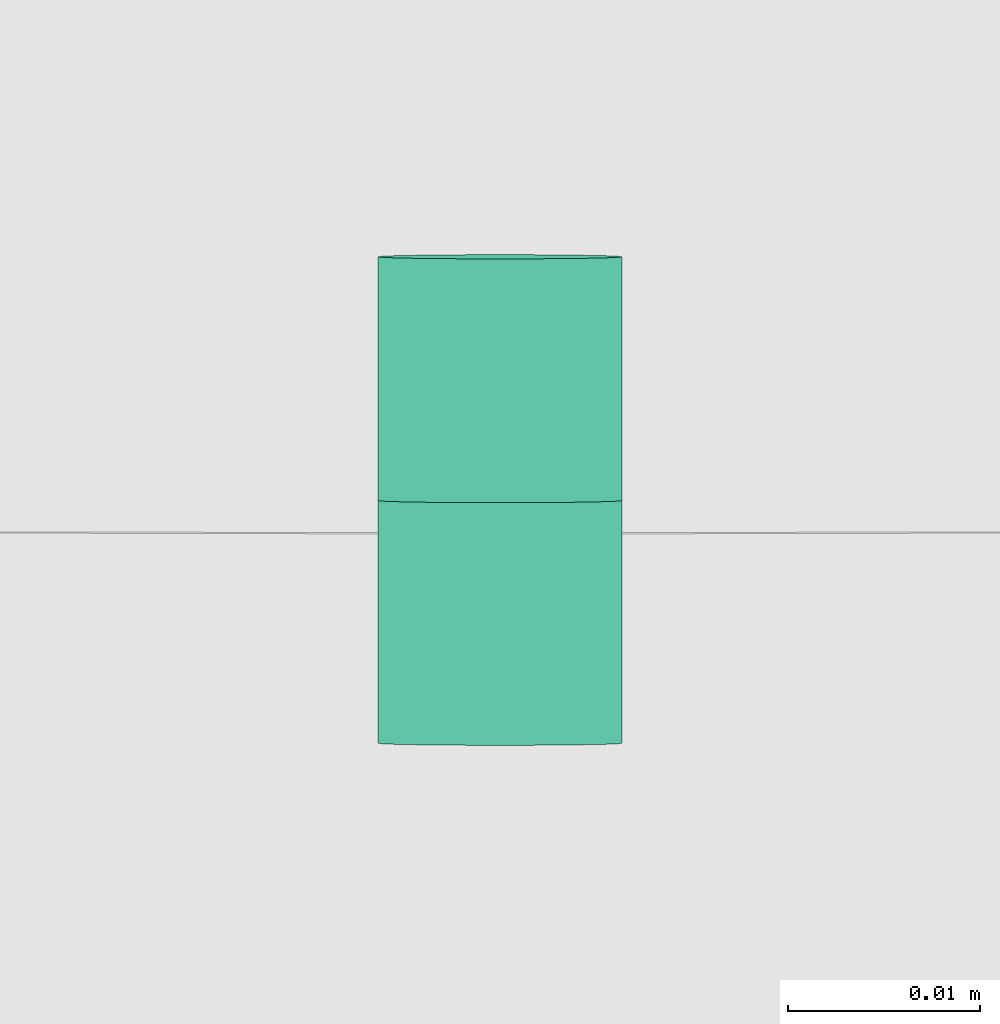
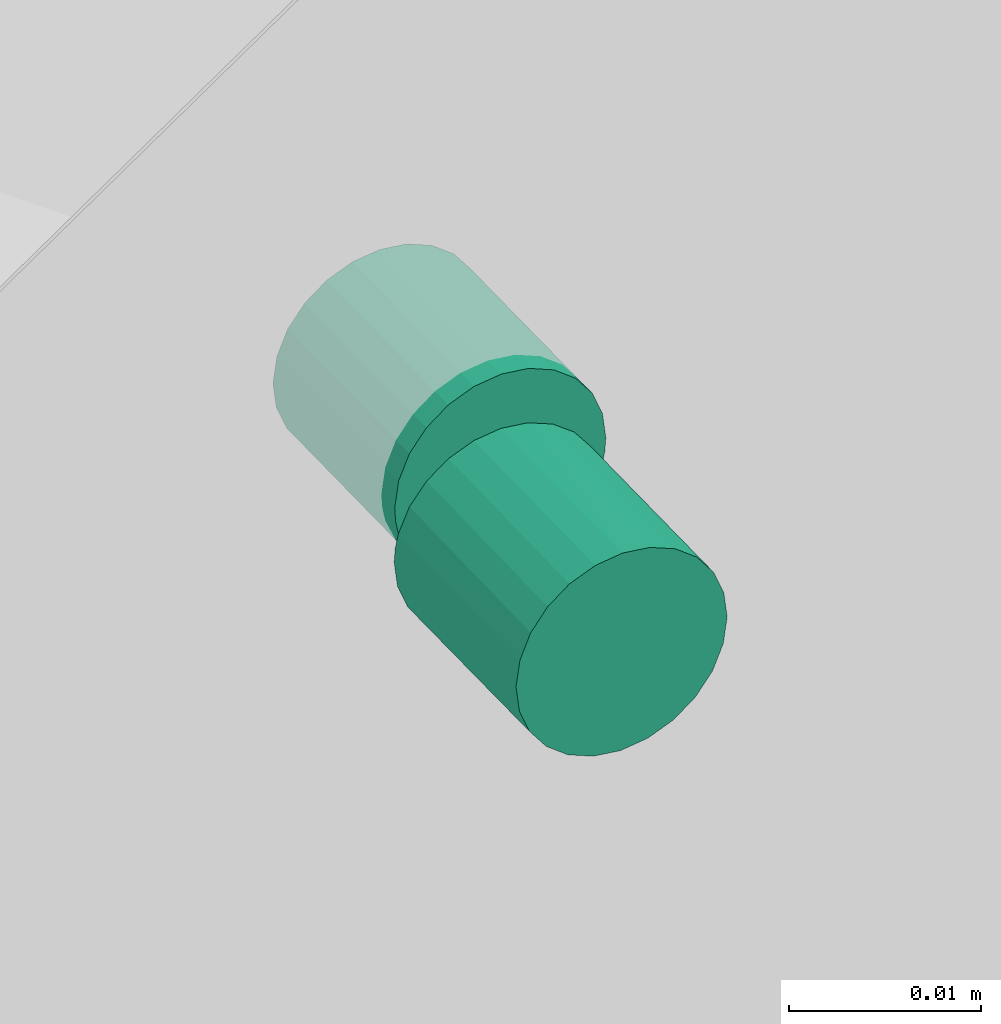
# One storey, part 60 of 60: 1 flow fitting.
"""IFC2X3 building model written with IfcOpenShell, lengths in millimetres."""

import ifcopenshell
import ifcopenshell.guid

model = None  # the IFC model being written
_history = None  # IfcOwnerHistory: only IFC2X3 demands one
_inside = {}  # id of a spatial element -> (the spatial element, [elements in it])
_under = {}  # id of a project, library or spatial element -> (it, [spatial elements below it])
_declared = {}  # id of a project -> (the project, [libraries it declares])
_typed = {}  # id of a type object -> (the type object, [elements of that type])
_made_of = {}  # id of a material, layer set ... -> (it, [elements and type objects made of it])


def new_model(schema):
    """Start an empty IFC model of exactly this schema.

    Asked for "IFC4X3", IfcOpenShell would pick the latest addendum, in which some entities
    have other attributes; the version numbers below select the first issue.
    IFC2X3 requires an IfcOwnerHistory on every rooted entity: one is made here for all.
    """
    global model, _history
    if schema == "IFC4X3":
        model = ifcopenshell.file(schema_version=(4, 3, 0, 0))
    else:
        model = ifcopenshell.file(schema=schema)
    _inside.clear()
    _under.clear()
    _declared.clear()
    _typed.clear()
    _made_of.clear()
    _history = None
    if model.schema == "IFC2X3":
        org = make("IfcOrganization", Name="unknown")
        user = make(
            "IfcPersonAndOrganization",
            ThePerson=make("IfcPerson", FamilyName="unknown"),
            TheOrganization=org,
        )
        app = make(
            "IfcApplication",
            ApplicationDeveloper=org,
            Version="unknown",
            ApplicationFullName="unknown",
            ApplicationIdentifier="unknown",
        )
        _history = make(
            "IfcOwnerHistory",
            OwningUser=user,
            OwningApplication=app,
            ChangeAction="ADDED",
            CreationDate=0,
        )
    return model


def make(cls, **values):
    """One entity of the class cls with the attributes given. An attribute that is None is left unset."""
    return model.create_entity(
        cls, **{name: value for name, value in values.items() if value is not None}
    )


def entity(cls, *values):
    """Any entity or typed value of the class cls, its attributes in the order of the schema. None: left unset."""
    e = model.create_entity(cls)
    for i, value in enumerate(values):
        if value is not None:
            e[i] = value
    return e


def rooted(cls, **values):
    """An entity with a GlobalId (a new one), such as an element, a storey or a relation."""
    return make(cls, GlobalId=ifcopenshell.guid.new(), OwnerHistory=_history, **values)


def si_unit(unit_type, name, prefix=None):
    """IfcSIUnit, for example si_unit("LENGTHUNIT", "METRE", prefix="MILLI")."""
    return make("IfcSIUnit", UnitType=unit_type, Prefix=prefix, Name=name)


def converted_unit(unit_type, name, factor, base, dimensions=None, offset=None):
    """IfcConversionBasedUnit, such as the inch: factor (a typed value) times the base unit."""
    return make(
        "IfcConversionBasedUnit"
        if offset is None
        else "IfcConversionBasedUnitWithOffset",
        ConversionOffset=offset,
        Dimensions=None
        if dimensions is None
        else entity("IfcDimensionalExponents", *dimensions),
        UnitType=unit_type,
        Name=name,
        ConversionFactor=make(
            "IfcMeasureWithUnit", ValueComponent=factor, UnitComponent=base
        ),
    )


def derived_unit(unit_type, elements):
    """IfcDerivedUnit: a product of units, each with its exponent."""
    return make(
        "IfcDerivedUnit",
        Elements=[
            make("IfcDerivedUnitElement", Unit=unit, Exponent=power)
            for unit, power in elements
        ],
        UnitType=unit_type,
    )


def assignment(units):
    """IfcUnitAssignment: the units of a project."""
    return None if units is None else make("IfcUnitAssignment", Units=units)


def point(xyz):
    """IfcCartesianPoint."""
    return None if xyz is None else make("IfcCartesianPoint", Coordinates=xyz)


def direction(xyz):
    """IfcDirection."""
    return None if xyz is None else make("IfcDirection", DirectionRatios=xyz)


def frame(location, z_axis=None, x_axis=None):
    """IfcAxis2Placement3D, a coordinate frame: its origin and axes. An axis left out is left unset."""
    return make(
        "IfcAxis2Placement3D",
        Location=point(location),
        Axis=direction(z_axis),
        RefDirection=direction(x_axis),
    )


def origin():
    """The frame at (0, 0, 0) with its axes left unset."""
    return frame((0.0, 0.0, 0.0))


def place(relative_to, where):
    """IfcLocalPlacement: puts the frame where relative to a parent placement (None: the world)."""
    return make(
        "IfcLocalPlacement", PlacementRelTo=relative_to, RelativePlacement=where
    )


def context(
    kind, dimensions, precision=None, world=None, true_north=None, identifier=None
):
    """IfcGeometricRepresentationContext, for example the 3D "Model" context."""
    return make(
        "IfcGeometricRepresentationContext",
        ContextIdentifier=identifier,
        ContextType=kind,
        CoordinateSpaceDimension=dimensions,
        Precision=precision,
        WorldCoordinateSystem=world,
        TrueNorth=true_north,
    )


def subcontext(parent, identifier, kind, view, scale=None):
    """IfcGeometricRepresentationSubContext, for example "Body" below "Model"."""
    return make(
        "IfcGeometricRepresentationSubContext",
        ContextIdentifier=identifier,
        ContextType=kind,
        ParentContext=parent,
        TargetScale=scale,
        TargetView=view,
    )


def project(units=None, contexts=None):
    """IfcProject with its units and contexts."""
    return rooted(
        "IfcProject",
        Name="project",
        RepresentationContexts=contexts,
        UnitsInContext=assignment(units),
    )


def spatial(cls, under=None, at=None, **own):
    """A site, building, storey or space (cls), placed at a placement, below another one or the project."""
    s = rooted(cls, ObjectPlacement=at, **own)
    if under is not None:
        _under.setdefault(under.id(), (under, []))[1].append(s)
    return s


def faces_of(points, faces, orient=None, outer=None):
    """IfcFace entities. A face is a list of loops; a loop is a list of indices into points, from 0.

    orient and outer hold one flag for each loop. By default every Orientation is true, the
    first loop of a face is its IfcFaceOuterBound and the others are IfcFaceBound.
    """
    made = []
    for i, loops in enumerate(faces):
        bounds = []
        for j, loop in enumerate(loops):
            is_outer = j == 0 if outer is None else outer[i][j]
            bounds.append(
                make(
                    "IfcFaceOuterBound" if is_outer else "IfcFaceBound",
                    Bound=make("IfcPolyLoop", Polygon=[points[k] for k in loop]),
                    Orientation=True if orient is None else orient[i][j],
                )
            )
        made.append(make("IfcFace", Bounds=bounds))
    return made


def faceted_brep(points, faces, orient=None, outer=None, voids=None):
    """IfcFacetedBrep: a solid bounded by flat faces; with voids (closed shells), ...WithVoids."""
    shared = [point(p) for p in points]
    hull = make("IfcClosedShell", CfsFaces=faces_of(shared, faces, orient, outer))
    if voids is None:
        return make("IfcFacetedBrep", Outer=hull)
    return make(
        "IfcFacetedBrepWithVoids",
        Outer=hull,
        Voids=[
            make(cls, CfsFaces=faces_of(shared, fs, o, b)) for cls, fs, o, b in voids
        ],
    )


def shape(context_of_items, identifier, shape_type, items):
    """IfcShapeRepresentation: the items that make up one representation, for example the "Body"."""
    return make(
        "IfcShapeRepresentation",
        ContextOfItems=context_of_items,
        RepresentationIdentifier=identifier,
        RepresentationType=shape_type,
        Items=items,
    )


def source(mapping_origin, context_of_items, identifier, shape_type, items):
    """IfcRepresentationMap: a shape defined once, which mapped items show again and again."""
    return make(
        "IfcRepresentationMap",
        MappingOrigin=mapping_origin,
        MappedRepresentation=shape(context_of_items, identifier, shape_type, items),
    )


def transform(
    local_origin,
    x_axis=None,
    y_axis=None,
    z_axis=None,
    scale=None,
    scale2=None,
    scale3=None,
    uniform=True,
):
    """IfcCartesianTransformationOperator3D, or its non-uniform kind. x_axis, y_axis, z_axis: its Axis1, 2, 3."""
    if uniform:
        return make(
            "IfcCartesianTransformationOperator3D",
            Axis1=direction(x_axis),
            Axis2=direction(y_axis),
            LocalOrigin=point(local_origin),
            Scale=scale,
            Axis3=direction(z_axis),
        )
    return make(
        "IfcCartesianTransformationOperator3DnonUniform",
        Axis1=direction(x_axis),
        Axis2=direction(y_axis),
        LocalOrigin=point(local_origin),
        Scale=scale,
        Axis3=direction(z_axis),
        Scale2=scale2,
        Scale3=scale3,
    )


def mapped(mapping_source, mapping_target):
    """IfcMappedItem: shows the shape of a source again, moved by a transform."""
    return make(
        "IfcMappedItem", MappingSource=mapping_source, MappingTarget=mapping_target
    )


def material(Name=None, Category=None):
    """IfcMaterial."""
    return make("IfcMaterial", Name=Name, Category=Category)


def made_of(thing, what):
    """Note that an element or type object is made of a material, layer set ...; save() writes the relation."""
    if what is not None:
        _made_of.setdefault(what.id(), (what, []))[1].append(thing)
    return thing


def type_object(cls, material=None, **own):
    """A type object (cls), such as IfcWallType, which elements share."""
    return made_of(rooted(cls, **own), material)


def type_shapes(of_type, sources):
    """Give a type object the sources (RepresentationMaps) that its elements show as mapped items."""
    of_type.RepresentationMaps = sources


def element(
    cls,
    number,
    at=None,
    inside=None,
    cuts=None,
    type_object=None,
    material=None,
    context=None,
    identifier="Body",
    shape_type=None,
    held_by="IfcProductDefinitionShape",
    body=None,
    shapes=None,
    **own,
):
    """One element of the class cls, such as IfcWall. Its Tag is "e" and its number.

    at: its placement. inside: the storey or other place that contains it. cuts: it is an
    opening in that element (IfcRelVoidsElement). A single representation is given by context,
    identifier, shape_type and body (its items); several are given by shapes. held_by: the class
    of the entity that holds the representations. save() writes the other relations.
    """
    e = rooted(cls, Tag="e%d" % number, ObjectPlacement=at, **own)
    if body is not None:
        shapes = [shape(context, identifier, shape_type, body)]
    if shapes is not None:
        e.Representation = make(held_by, Representations=shapes)
    if inside is not None:
        _inside.setdefault(inside.id(), (inside, []))[1].append(e)
    if cuts is not None:
        rooted(
            "IfcRelVoidsElement", RelatingBuildingElement=cuts, RelatedOpeningElement=e
        )
    if type_object is not None:
        _typed.setdefault(type_object.id(), (type_object, []))[1].append(e)
    return made_of(e, material)


def aggregate(whole, parts):
    """IfcRelAggregates: a whole, such as a stair, and the parts it consists of."""
    return rooted("IfcRelAggregates", RelatingObject=whole, RelatedObjects=parts)


def save(model, path):
    """Write the relations noted so far, then the file.

    IfcRelAggregates (storeys below a building ...), IfcRelContainedInSpatialStructure (elements
    in a storey), IfcRelDefinesByType, IfcRelAssociatesMaterial and IfcRelDeclares: one each for
    every whole, place, type object, material and project.
    """
    for whole, parts in _under.values():
        aggregate(whole, parts)
    for where, things in _inside.values():
        rooted(
            "IfcRelContainedInSpatialStructure",
            RelatedElements=things,
            RelatingStructure=where,
        )
    for kind, things in _typed.values():
        rooted("IfcRelDefinesByType", RelatedObjects=things, RelatingType=kind)
    for what, things in _made_of.values():
        rooted("IfcRelAssociatesMaterial", RelatedObjects=things, RelatingMaterial=what)
    for by, libraries in _declared.values():
        rooted("IfcRelDeclares", RelatingContext=by, RelatedDefinitions=libraries)
    model.write(path)


model = new_model("IFC2X3")

# Units and contexts
model_context = context("Model", 3, precision=0.01, world=origin(), true_north=direction((6.12303176911189e-17, 1.0)))
body_context = subcontext(model_context, "Body", "Model", "MODEL_VIEW")
ifc_project = project(units=[si_unit("LENGTHUNIT", "METRE", prefix="MILLI"), si_unit("AREAUNIT", "SQUARE_METRE"), si_unit("VOLUMEUNIT", "CUBIC_METRE"), converted_unit("PLANEANGLEUNIT", "DEGREE", entity("IfcRatioMeasure", 0.0174532925199433), si_unit("PLANEANGLEUNIT", "RADIAN"), dimensions=[0, 0, 0, 0, 0, 0, 0]), si_unit("MASSUNIT", "GRAM", prefix="KILO"), derived_unit("MASSDENSITYUNIT", [(si_unit("MASSUNIT", "GRAM", prefix="KILO"), 1), (si_unit("LENGTHUNIT", "METRE"), -3)]), derived_unit("MOMENTOFINERTIAUNIT", [(si_unit("LENGTHUNIT", "METRE"), 4)]), si_unit("TIMEUNIT", "SECOND"), si_unit("FREQUENCYUNIT", "HERTZ"), si_unit("THERMODYNAMICTEMPERATUREUNIT", "DEGREE_CELSIUS"), derived_unit("THERMALTRANSMITTANCEUNIT", [(si_unit("MASSUNIT", "GRAM", prefix="KILO"), 1), (si_unit("THERMODYNAMICTEMPERATUREUNIT", "KELVIN"), -1), (si_unit("TIMEUNIT", "SECOND"), -3)]), derived_unit("VOLUMETRICFLOWRATEUNIT", [(si_unit("LENGTHUNIT", "METRE"), 3), (si_unit("TIMEUNIT", "SECOND"), -1)]), derived_unit("MASSFLOWRATEUNIT", [(si_unit("MASSUNIT", "GRAM", prefix="KILO"), 1), (si_unit("TIMEUNIT", "SECOND"), -1)]), derived_unit("ROTATIONALFREQUENCYUNIT", [(si_unit("TIMEUNIT", "SECOND"), -1)]), si_unit("ELECTRICCURRENTUNIT", "AMPERE"), si_unit("ELECTRICVOLTAGEUNIT", "VOLT"), si_unit("POWERUNIT", "WATT"), si_unit("FORCEUNIT", "NEWTON", prefix="KILO"), si_unit("ILLUMINANCEUNIT", "LUX"), si_unit("LUMINOUSFLUXUNIT", "LUMEN"), si_unit("LUMINOUSINTENSITYUNIT", "CANDELA"), derived_unit("USERDEFINED", [(si_unit("MASSUNIT", "GRAM", prefix="KILO"), -1), (si_unit("LENGTHUNIT", "METRE"), -2), (si_unit("TIMEUNIT", "SECOND"), 3), (si_unit("LUMINOUSFLUXUNIT", "LUMEN"), 1)]), derived_unit("LINEARVELOCITYUNIT", [(si_unit("LENGTHUNIT", "METRE"), 1), (si_unit("TIMEUNIT", "SECOND"), -1)]), si_unit("PRESSUREUNIT", "PASCAL"), derived_unit("USERDEFINED", [(si_unit("LENGTHUNIT", "METRE"), -2), (si_unit("MASSUNIT", "GRAM", prefix="KILO"), 1), (si_unit("TIMEUNIT", "SECOND"), -2)]), derived_unit("LINEARFORCEUNIT", [(si_unit("MASSUNIT", "GRAM", prefix="KILO"), 1), (si_unit("LENGTHUNIT", "METRE"), 1), (si_unit("TIMEUNIT", "SECOND"), -2), (si_unit("LENGTHUNIT", "METRE"), -1)]), derived_unit("PLANARFORCEUNIT", [(si_unit("MASSUNIT", "GRAM", prefix="KILO"), 1), (si_unit("LENGTHUNIT", "METRE"), 1), (si_unit("TIMEUNIT", "SECOND"), -2), (si_unit("LENGTHUNIT", "METRE"), -2)])], contexts=[model_context])

# Site, building, storey
site_placement = place(None, origin())
site = spatial("IfcSite", under=ifc_project, at=site_placement, CompositionType="ELEMENT")
building_placement = place(site_placement, origin())
building = spatial("IfcBuilding", under=site, at=building_placement, CompositionType="ELEMENT")
storey_placement = place(building_placement, frame((0.0, 0.0, 19800.0)))
storey = spatial("IfcBuildingStorey", under=building, at=storey_placement, CompositionType="ELEMENT", Elevation=19800.0)

# Flow fitting
ifc_material = material()
duct_fitting_type = type_object("IfcDuctFittingType", PredefinedType="NOTDEFINED", material=ifc_material)
shared_shape = source(origin(), body_context, "Body", "Brep", [
    faceted_brep([(0.0, -5.46, 3.25), (0.0, -4.44, 4.54), (0.0, -3.14, 5.52), (0.0, -1.62, 6.14), (0.0, 0.0, 6.35), (0.0, 1.62, 6.14), (0.0, 3.14, 5.52), (0.0, 4.44, 4.54), (0.0, 5.46, 3.25), (0.0, 6.11, 1.75), (0.0, 6.29, 2.61), (0.0, 6.35, 3.49), (0.0, 6.13, 5.14), (0.0, 5.5, 6.67), (0.0, 4.49, 7.98), (0.0, 3.17, 8.99), (0.0, 1.64, 9.63), (0.0, 0.0, 9.84), (0.0, -1.64, 9.63), (0.0, -3.18, 8.99), (0.0, -4.49, 7.98), (0.0, -5.5, 6.67), (0.0, -6.13, 5.14), (0.0, -6.35, 3.49), (0.0, -6.29, 2.61), (0.0, -6.11, 1.75), (-12.7, -1.64, -2.64), (-12.7, -3.18, -2.01), (-12.7, -4.49, -1.0), (-12.7, -5.5, 0.32), (-12.7, -6.13, 1.85), (-12.7, -6.35, 3.49), (-12.7, -6.13, 5.14), (-12.7, -5.5, 6.67), (-12.7, -4.49, 7.98), (-12.7, -3.18, 8.99), (-12.7, -1.64, 9.63), (-12.7, 0.0, 9.84), (-12.7, 1.64, 9.63), (-12.7, 3.17, 8.99), (-12.7, 4.49, 7.98), (-12.7, 5.5, 6.67), (-12.7, 6.13, 5.14), (-12.7, 6.35, 3.49), (-12.7, 6.13, 1.85), (-12.7, 5.5, 0.32), (-12.7, 4.49, -1.0), (-12.7, 3.17, -2.01), (-12.7, 1.64, -2.64), (-12.7, 0.0, -2.86), (0.0, -4.44, -1.04), (0.0, -3.14, -2.03), (0.0, -5.46, 0.24), (0.0, -1.62, -2.65), (0.0, 0.0, -2.86), (0.0, 3.14, -2.03), (0.0, 4.44, -1.04), (0.0, 5.46, 0.24), (0.0, 1.62, -2.65), (0.0, 3.18, -5.5), (0.0, 1.64, -6.13), (0.0, 0.0, -6.35), (0.0, -1.64, -6.13), (0.0, -3.17, -5.5), (0.0, -4.49, -4.49), (0.0, -5.5, -3.18), (0.0, -6.13, -1.64), (0.0, -6.35, 0.0), (0.0, -6.29, 0.89), (0.0, 6.29, 0.89), (0.0, 6.35, 0.0), (0.0, 6.13, -1.64), (0.0, 5.5, -3.18), (0.0, 4.49, -4.49), (12.7, 0.0, -6.35), (12.7, 1.64, -6.13), (12.7, 3.18, -5.5), (12.7, 4.49, -4.49), (12.7, 5.5, -3.18), (12.7, 6.13, -1.64), (12.7, 6.35, 0.0), (12.7, 6.13, 1.64), (12.7, 5.5, 3.17), (12.7, 4.49, 4.49), (12.7, 3.17, 5.5), (12.7, 1.64, 6.13), (12.7, 0.0, 6.35), (12.7, -1.64, 6.13), (12.7, -3.18, 5.5), (12.7, -4.49, 4.49), (12.7, -5.5, 3.17), (12.7, -6.13, 1.64), (12.7, -6.35, 0.0), (12.7, -6.13, -1.64), (12.7, -5.5, -3.18), (12.7, -4.49, -4.49), (12.7, -3.17, -5.5), (12.7, -1.64, -6.13)], [[[0, 1, 2, 3, 4, 5, 6, 7, 8, 9, 10, 11, 12, 13, 14, 15, 16, 17, 18, 19, 20, 21, 22, 23, 24, 25]], [[26, 27, 28, 29, 30, 31, 32, 33, 34, 35, 36, 37, 38, 39, 40, 41, 42, 43, 44, 45, 46, 47, 48, 49]], [[42, 12, 11, 43]], [[41, 13, 12, 42]], [[14, 40, 39, 15]], [[41, 40, 14, 13]], [[15, 39, 38, 16]], [[16, 38, 37, 17]], [[35, 19, 18, 36]], [[34, 20, 19, 35]], [[21, 33, 32, 22]], [[34, 33, 21, 20]], [[22, 32, 31, 23]], [[18, 17, 37, 36]], [[30, 24, 31]], [[29, 25, 30]], [[50, 28, 27]], [[27, 26, 51]], [[29, 28, 52]], [[49, 53, 26]], [[30, 25, 24]], [[24, 23, 31]], [[51, 50, 27]], [[52, 28, 50]], [[25, 29, 52]], [[26, 53, 51]], [[49, 54, 53]], [[47, 55, 48]], [[46, 56, 47]], [[9, 45, 44]], [[44, 43, 10]], [[46, 45, 57]], [[11, 10, 43]], [[48, 55, 58]], [[54, 49, 58]], [[57, 45, 9]], [[56, 46, 57]], [[56, 55, 47]], [[44, 10, 9]], [[58, 49, 48]], [[59, 60, 61, 62, 63, 64, 65, 66, 67, 68, 25, 52, 50, 51, 53, 54, 58, 55, 56, 57, 9, 69, 70, 71, 72, 73]], [[74, 75, 76, 77, 78, 79, 80, 81, 82, 83, 84, 85, 86, 87, 88, 89, 90, 91, 92, 93, 94, 95, 96, 97]], [[91, 68, 92]], [[90, 25, 91]], [[1, 89, 88]], [[88, 87, 2]], [[90, 89, 0]], [[86, 3, 87]], [[92, 68, 67]], [[68, 91, 25]], [[2, 1, 88]], [[0, 89, 1]], [[0, 25, 90]], [[2, 87, 3]], [[86, 4, 3]], [[84, 6, 85]], [[83, 7, 84]], [[9, 82, 81]], [[81, 80, 69]], [[83, 82, 8]], [[70, 69, 80]], [[85, 6, 5]], [[4, 86, 5]], [[69, 9, 81]], [[7, 83, 8]], [[7, 6, 84]], [[82, 9, 8]], [[5, 86, 85]], [[79, 71, 70, 80]], [[78, 72, 71, 79]], [[73, 77, 76, 59]], [[78, 77, 73, 72]], [[59, 76, 75, 60]], [[60, 75, 74, 61]], [[96, 63, 62, 97]], [[95, 64, 63, 96]], [[65, 94, 93, 66]], [[95, 94, 65, 64]], [[66, 93, 92, 67]], [[62, 61, 74, 97]]]),
])
type_shapes(duct_fitting_type, [shared_shape])
flow_fitting_placement = place(storey_placement, frame((31495.56, 9600.35, 3181.51), z_axis=(0.0, -0.0174622026315394, 0.99984752411518), x_axis=(0.0, -0.99984752411518, -0.0174622026315394)))
element("IfcFlowFitting", 1, at=flow_fitting_placement, inside=storey, type_object=duct_fitting_type, material=ifc_material, context=body_context, shape_type="MappedRepresentation", body=[
    mapped(shared_shape, transform((0.0, 0.0, 0.0), scale=1.0)),
])

save(model, "model.ifc")
